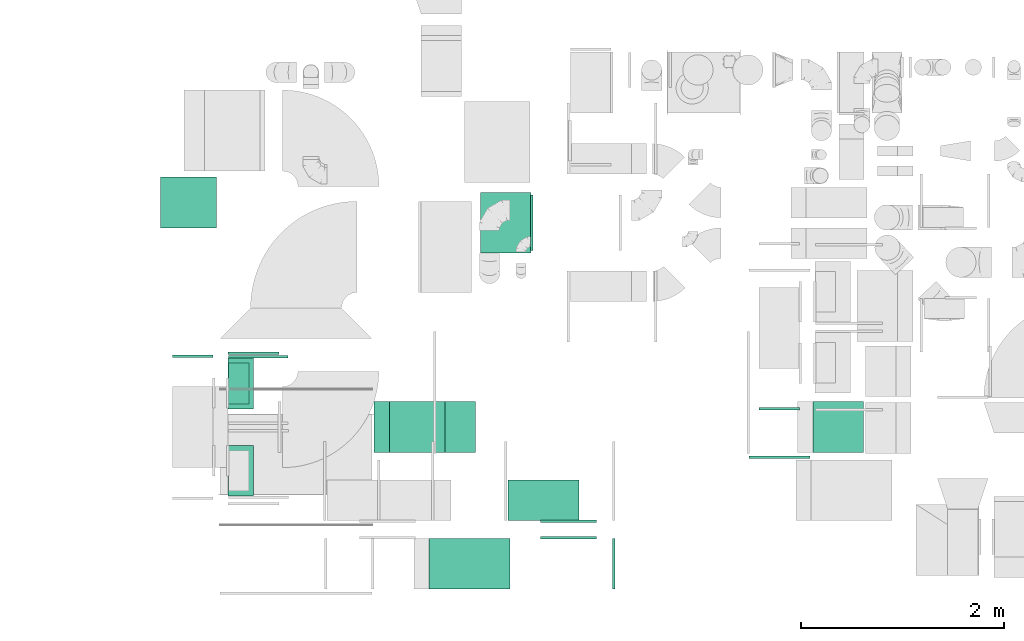
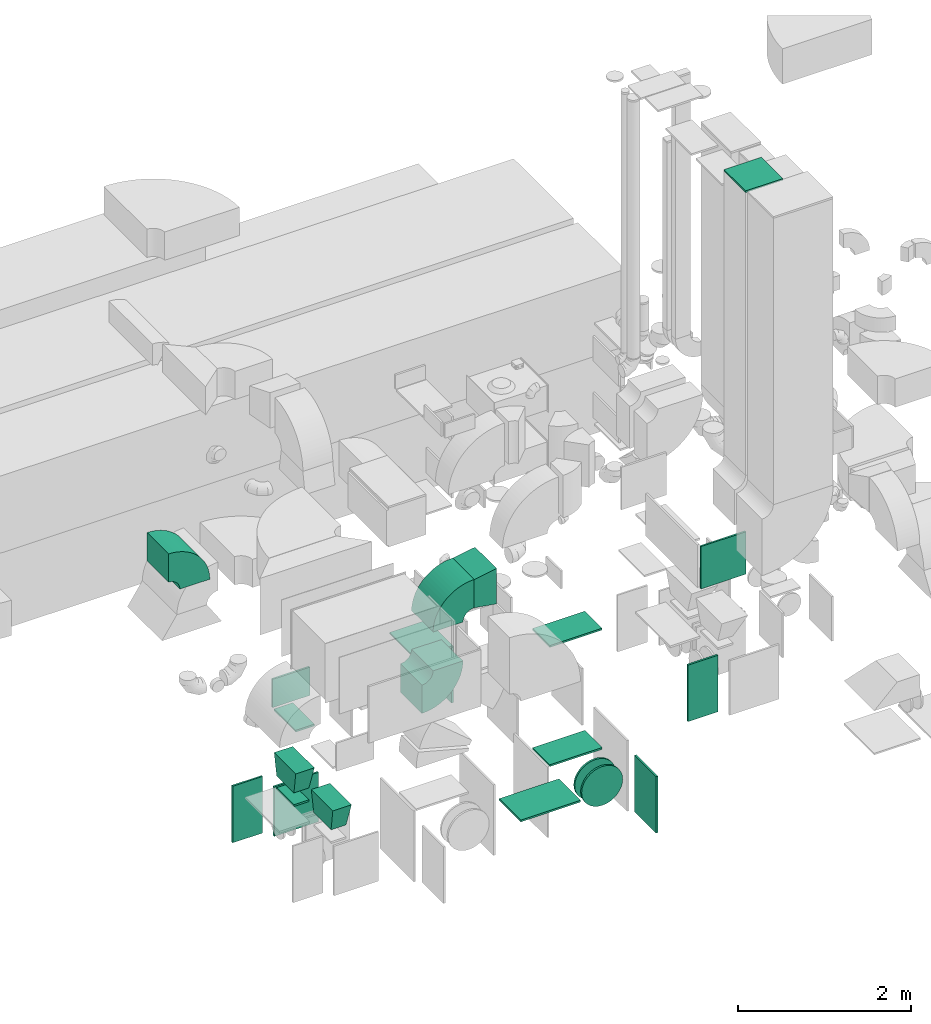
# One storey, part 14 of 59: 22 flow fittings.
"""IFC2X3 building model written with IfcOpenShell, lengths in millimetres."""

import ifcopenshell
import ifcopenshell.guid

model = None  # the IFC model being written
_history = None  # IfcOwnerHistory: only IFC2X3 demands one
_inside = {}  # id of a spatial element -> (the spatial element, [elements in it])
_under = {}  # id of a project, library or spatial element -> (it, [spatial elements below it])
_declared = {}  # id of a project -> (the project, [libraries it declares])
_typed = {}  # id of a type object -> (the type object, [elements of that type])
_made_of = {}  # id of a material, layer set ... -> (it, [elements and type objects made of it])


def new_model(schema):
    """Start an empty IFC model of exactly this schema.

    Asked for "IFC4X3", IfcOpenShell would pick the latest addendum, in which some entities
    have other attributes; the version numbers below select the first issue.
    IFC2X3 requires an IfcOwnerHistory on every rooted entity: one is made here for all.
    """
    global model, _history
    if schema == "IFC4X3":
        model = ifcopenshell.file(schema_version=(4, 3, 0, 0))
    else:
        model = ifcopenshell.file(schema=schema)
    _inside.clear()
    _under.clear()
    _declared.clear()
    _typed.clear()
    _made_of.clear()
    _history = None
    if model.schema == "IFC2X3":
        org = make("IfcOrganization", Name="unknown")
        user = make(
            "IfcPersonAndOrganization",
            ThePerson=make("IfcPerson", FamilyName="unknown"),
            TheOrganization=org,
        )
        app = make(
            "IfcApplication",
            ApplicationDeveloper=org,
            Version="unknown",
            ApplicationFullName="unknown",
            ApplicationIdentifier="unknown",
        )
        _history = make(
            "IfcOwnerHistory",
            OwningUser=user,
            OwningApplication=app,
            ChangeAction="ADDED",
            CreationDate=0,
        )
    return model


def make(cls, **values):
    """One entity of the class cls with the attributes given. An attribute that is None is left unset."""
    return model.create_entity(
        cls, **{name: value for name, value in values.items() if value is not None}
    )


def entity(cls, *values):
    """Any entity or typed value of the class cls, its attributes in the order of the schema. None: left unset."""
    e = model.create_entity(cls)
    for i, value in enumerate(values):
        if value is not None:
            e[i] = value
    return e


def rooted(cls, **values):
    """An entity with a GlobalId (a new one), such as an element, a storey or a relation."""
    return make(cls, GlobalId=ifcopenshell.guid.new(), OwnerHistory=_history, **values)


def si_unit(unit_type, name, prefix=None):
    """IfcSIUnit, for example si_unit("LENGTHUNIT", "METRE", prefix="MILLI")."""
    return make("IfcSIUnit", UnitType=unit_type, Prefix=prefix, Name=name)


def converted_unit(unit_type, name, factor, base, dimensions=None, offset=None):
    """IfcConversionBasedUnit, such as the inch: factor (a typed value) times the base unit."""
    return make(
        "IfcConversionBasedUnit"
        if offset is None
        else "IfcConversionBasedUnitWithOffset",
        ConversionOffset=offset,
        Dimensions=None
        if dimensions is None
        else entity("IfcDimensionalExponents", *dimensions),
        UnitType=unit_type,
        Name=name,
        ConversionFactor=make(
            "IfcMeasureWithUnit", ValueComponent=factor, UnitComponent=base
        ),
    )


def derived_unit(unit_type, elements):
    """IfcDerivedUnit: a product of units, each with its exponent."""
    return make(
        "IfcDerivedUnit",
        Elements=[
            make("IfcDerivedUnitElement", Unit=unit, Exponent=power)
            for unit, power in elements
        ],
        UnitType=unit_type,
    )


def assignment(units):
    """IfcUnitAssignment: the units of a project."""
    return None if units is None else make("IfcUnitAssignment", Units=units)


def point(xyz):
    """IfcCartesianPoint."""
    return None if xyz is None else make("IfcCartesianPoint", Coordinates=xyz)


def direction(xyz):
    """IfcDirection."""
    return None if xyz is None else make("IfcDirection", DirectionRatios=xyz)


def frame(location, z_axis=None, x_axis=None):
    """IfcAxis2Placement3D, a coordinate frame: its origin and axes. An axis left out is left unset."""
    return make(
        "IfcAxis2Placement3D",
        Location=point(location),
        Axis=direction(z_axis),
        RefDirection=direction(x_axis),
    )


def frame_2d(location, x_axis=None):
    """IfcAxis2Placement2D, a coordinate frame in the plane: its origin and x axis."""
    return make(
        "IfcAxis2Placement2D", Location=point(location), RefDirection=direction(x_axis)
    )


def origin():
    """The frame at (0, 0, 0) with its axes left unset."""
    return frame((0.0, 0.0, 0.0))


def origin_2d_with_axis():
    """The frame at (0, 0) in the plane with the x axis (1, 0) written out."""
    return frame_2d((0.0, 0.0), x_axis=(1.0, 0.0))


def place(relative_to, where):
    """IfcLocalPlacement: puts the frame where relative to a parent placement (None: the world)."""
    return make(
        "IfcLocalPlacement", PlacementRelTo=relative_to, RelativePlacement=where
    )


def context(
    kind, dimensions, precision=None, world=None, true_north=None, identifier=None
):
    """IfcGeometricRepresentationContext, for example the 3D "Model" context."""
    return make(
        "IfcGeometricRepresentationContext",
        ContextIdentifier=identifier,
        ContextType=kind,
        CoordinateSpaceDimension=dimensions,
        Precision=precision,
        WorldCoordinateSystem=world,
        TrueNorth=true_north,
    )


def subcontext(parent, identifier, kind, view, scale=None):
    """IfcGeometricRepresentationSubContext, for example "Body" below "Model"."""
    return make(
        "IfcGeometricRepresentationSubContext",
        ContextIdentifier=identifier,
        ContextType=kind,
        ParentContext=parent,
        TargetScale=scale,
        TargetView=view,
    )


def project(units=None, contexts=None):
    """IfcProject with its units and contexts."""
    return rooted(
        "IfcProject",
        Name="project",
        RepresentationContexts=contexts,
        UnitsInContext=assignment(units),
    )


def spatial(cls, under=None, at=None, **own):
    """A site, building, storey or space (cls), placed at a placement, below another one or the project."""
    s = rooted(cls, ObjectPlacement=at, **own)
    if under is not None:
        _under.setdefault(under.id(), (under, []))[1].append(s)
    return s


def polyline(points):
    """IfcPolyline through the points."""
    return make("IfcPolyline", Points=[point(p) for p in points])


def circle_curve(where, radius):
    """IfcCircle in the frame where."""
    return make("IfcCircle", Position=where, Radius=radius)


def parameter(value):
    """IfcParameterValue: where a trimmed curve begins or ends, as a parameter of its basis curve."""
    return model.create_entity("IfcParameterValue", value)


def trimmed(basis, trim1, trim2, sense, master):
    """IfcTrimmedCurve: the piece of a basis curve between two trims."""
    return make(
        "IfcTrimmedCurve",
        BasisCurve=basis,
        Trim1=trim1,
        Trim2=trim2,
        SenseAgreement=sense,
        MasterRepresentation=master,
    )


def segment(curve, same_sense, transition):
    """IfcCompositeCurveSegment."""
    return make(
        "IfcCompositeCurveSegment",
        Transition=transition,
        SameSense=same_sense,
        ParentCurve=curve,
    )


def composite_curve(segments, self_intersect=None):
    """IfcCompositeCurve: segments joined end to end."""
    return make("IfcCompositeCurve", Segments=segments, SelfIntersect=self_intersect)


def profile(cls, at=None, kind="AREA", **sizes):
    """A parametric profile (cls). Its sizes go by their IFC names, for example OverallWidth=200.0."""
    return make(cls, ProfileType=kind, Position=at, **sizes)


def rectangle(**sizes):
    """IfcRectangleProfileDef."""
    return profile("IfcRectangleProfileDef", **sizes)


def outline(outer, holes=None, kind="AREA"):
    """IfcArbitraryClosedProfileDef: a profile drawn as a closed curve; with holes, ...WithVoids."""
    if holes is None:
        return make("IfcArbitraryClosedProfileDef", ProfileType=kind, OuterCurve=outer)
    return make(
        "IfcArbitraryProfileDefWithVoids",
        ProfileType=kind,
        OuterCurve=outer,
        InnerCurves=holes,
    )


def extrude(swept, where, along, depth):
    """IfcExtrudedAreaSolid: the profile swept, set in the frame where, extruded along a direction by depth."""
    return make(
        "IfcExtrudedAreaSolid",
        SweptArea=swept,
        Position=where,
        ExtrudedDirection=direction(along),
        Depth=depth,
    )


def faces_of(points, faces, orient=None, outer=None):
    """IfcFace entities. A face is a list of loops; a loop is a list of indices into points, from 0.

    orient and outer hold one flag for each loop. By default every Orientation is true, the
    first loop of a face is its IfcFaceOuterBound and the others are IfcFaceBound.
    """
    made = []
    for i, loops in enumerate(faces):
        bounds = []
        for j, loop in enumerate(loops):
            is_outer = j == 0 if outer is None else outer[i][j]
            bounds.append(
                make(
                    "IfcFaceOuterBound" if is_outer else "IfcFaceBound",
                    Bound=make("IfcPolyLoop", Polygon=[points[k] for k in loop]),
                    Orientation=True if orient is None else orient[i][j],
                )
            )
        made.append(make("IfcFace", Bounds=bounds))
    return made


def faceted_brep(points, faces, orient=None, outer=None, voids=None):
    """IfcFacetedBrep: a solid bounded by flat faces; with voids (closed shells), ...WithVoids."""
    shared = [point(p) for p in points]
    hull = make("IfcClosedShell", CfsFaces=faces_of(shared, faces, orient, outer))
    if voids is None:
        return make("IfcFacetedBrep", Outer=hull)
    return make(
        "IfcFacetedBrepWithVoids",
        Outer=hull,
        Voids=[
            make(cls, CfsFaces=faces_of(shared, fs, o, b)) for cls, fs, o, b in voids
        ],
    )


def shape(context_of_items, identifier, shape_type, items):
    """IfcShapeRepresentation: the items that make up one representation, for example the "Body"."""
    return make(
        "IfcShapeRepresentation",
        ContextOfItems=context_of_items,
        RepresentationIdentifier=identifier,
        RepresentationType=shape_type,
        Items=items,
    )


def source(mapping_origin, context_of_items, identifier, shape_type, items):
    """IfcRepresentationMap: a shape defined once, which mapped items show again and again."""
    return make(
        "IfcRepresentationMap",
        MappingOrigin=mapping_origin,
        MappedRepresentation=shape(context_of_items, identifier, shape_type, items),
    )


def transform(
    local_origin,
    x_axis=None,
    y_axis=None,
    z_axis=None,
    scale=None,
    scale2=None,
    scale3=None,
    uniform=True,
):
    """IfcCartesianTransformationOperator3D, or its non-uniform kind. x_axis, y_axis, z_axis: its Axis1, 2, 3."""
    if uniform:
        return make(
            "IfcCartesianTransformationOperator3D",
            Axis1=direction(x_axis),
            Axis2=direction(y_axis),
            LocalOrigin=point(local_origin),
            Scale=scale,
            Axis3=direction(z_axis),
        )
    return make(
        "IfcCartesianTransformationOperator3DnonUniform",
        Axis1=direction(x_axis),
        Axis2=direction(y_axis),
        LocalOrigin=point(local_origin),
        Scale=scale,
        Axis3=direction(z_axis),
        Scale2=scale2,
        Scale3=scale3,
    )


def mapped(mapping_source, mapping_target):
    """IfcMappedItem: shows the shape of a source again, moved by a transform."""
    return make(
        "IfcMappedItem", MappingSource=mapping_source, MappingTarget=mapping_target
    )


def material(Name=None, Category=None):
    """IfcMaterial."""
    return make("IfcMaterial", Name=Name, Category=Category)


def made_of(thing, what):
    """Note that an element or type object is made of a material, layer set ...; save() writes the relation."""
    if what is not None:
        _made_of.setdefault(what.id(), (what, []))[1].append(thing)
    return thing


def type_object(cls, material=None, **own):
    """A type object (cls), such as IfcWallType, which elements share."""
    return made_of(rooted(cls, **own), material)


def type_shapes(of_type, sources):
    """Give a type object the sources (RepresentationMaps) that its elements show as mapped items."""
    of_type.RepresentationMaps = sources


def element(
    cls,
    number,
    at=None,
    inside=None,
    cuts=None,
    type_object=None,
    material=None,
    context=None,
    identifier="Body",
    shape_type=None,
    held_by="IfcProductDefinitionShape",
    body=None,
    shapes=None,
    **own,
):
    """One element of the class cls, such as IfcWall. Its Tag is "e" and its number.

    at: its placement. inside: the storey or other place that contains it. cuts: it is an
    opening in that element (IfcRelVoidsElement). A single representation is given by context,
    identifier, shape_type and body (its items); several are given by shapes. held_by: the class
    of the entity that holds the representations. save() writes the other relations.
    """
    e = rooted(cls, Tag="e%d" % number, ObjectPlacement=at, **own)
    if body is not None:
        shapes = [shape(context, identifier, shape_type, body)]
    if shapes is not None:
        e.Representation = make(held_by, Representations=shapes)
    if inside is not None:
        _inside.setdefault(inside.id(), (inside, []))[1].append(e)
    if cuts is not None:
        rooted(
            "IfcRelVoidsElement", RelatingBuildingElement=cuts, RelatedOpeningElement=e
        )
    if type_object is not None:
        _typed.setdefault(type_object.id(), (type_object, []))[1].append(e)
    return made_of(e, material)


def aggregate(whole, parts):
    """IfcRelAggregates: a whole, such as a stair, and the parts it consists of."""
    return rooted("IfcRelAggregates", RelatingObject=whole, RelatedObjects=parts)


def save(model, path):
    """Write the relations noted so far, then the file.

    IfcRelAggregates (storeys below a building ...), IfcRelContainedInSpatialStructure (elements
    in a storey), IfcRelDefinesByType, IfcRelAssociatesMaterial and IfcRelDeclares: one each for
    every whole, place, type object, material and project.
    """
    for whole, parts in _under.values():
        aggregate(whole, parts)
    for where, things in _inside.values():
        rooted(
            "IfcRelContainedInSpatialStructure",
            RelatedElements=things,
            RelatingStructure=where,
        )
    for kind, things in _typed.values():
        rooted("IfcRelDefinesByType", RelatedObjects=things, RelatingType=kind)
    for what, things in _made_of.values():
        rooted("IfcRelAssociatesMaterial", RelatedObjects=things, RelatingMaterial=what)
    for by, libraries in _declared.values():
        rooted("IfcRelDeclares", RelatingContext=by, RelatedDefinitions=libraries)
    model.write(path)


model = new_model("IFC2X3")

# Units and contexts
model_context = context("Model", 3, precision=0.01, world=origin(), true_north=direction((6.12303176911189e-17, 1.0)))
body_context = subcontext(model_context, "Body", "Model", "MODEL_VIEW")
ifc_project = project(units=[si_unit("LENGTHUNIT", "METRE", prefix="MILLI"), si_unit("AREAUNIT", "SQUARE_METRE"), si_unit("VOLUMEUNIT", "CUBIC_METRE"), converted_unit("PLANEANGLEUNIT", "DEGREE", entity("IfcRatioMeasure", 0.0174532925199433), si_unit("PLANEANGLEUNIT", "RADIAN"), dimensions=[0, 0, 0, 0, 0, 0, 0]), si_unit("MASSUNIT", "GRAM", prefix="KILO"), derived_unit("MASSDENSITYUNIT", [(si_unit("MASSUNIT", "GRAM", prefix="KILO"), 1), (si_unit("LENGTHUNIT", "METRE"), -3)]), derived_unit("MOMENTOFINERTIAUNIT", [(si_unit("LENGTHUNIT", "METRE"), 4)]), si_unit("TIMEUNIT", "SECOND"), si_unit("FREQUENCYUNIT", "HERTZ"), si_unit("THERMODYNAMICTEMPERATUREUNIT", "DEGREE_CELSIUS"), derived_unit("THERMALTRANSMITTANCEUNIT", [(si_unit("MASSUNIT", "GRAM", prefix="KILO"), 1), (si_unit("THERMODYNAMICTEMPERATUREUNIT", "KELVIN"), -1), (si_unit("TIMEUNIT", "SECOND"), -3)]), derived_unit("VOLUMETRICFLOWRATEUNIT", [(si_unit("LENGTHUNIT", "METRE"), 3), (si_unit("TIMEUNIT", "SECOND"), -1)]), derived_unit("MASSFLOWRATEUNIT", [(si_unit("MASSUNIT", "GRAM", prefix="KILO"), 1), (si_unit("TIMEUNIT", "SECOND"), -1)]), derived_unit("ROTATIONALFREQUENCYUNIT", [(si_unit("TIMEUNIT", "SECOND"), -1)]), si_unit("ELECTRICCURRENTUNIT", "AMPERE"), si_unit("ELECTRICVOLTAGEUNIT", "VOLT"), si_unit("POWERUNIT", "WATT"), si_unit("FORCEUNIT", "NEWTON", prefix="KILO"), si_unit("ILLUMINANCEUNIT", "LUX"), si_unit("LUMINOUSFLUXUNIT", "LUMEN"), si_unit("LUMINOUSINTENSITYUNIT", "CANDELA"), derived_unit("USERDEFINED", [(si_unit("MASSUNIT", "GRAM", prefix="KILO"), -1), (si_unit("LENGTHUNIT", "METRE"), -2), (si_unit("TIMEUNIT", "SECOND"), 3), (si_unit("LUMINOUSFLUXUNIT", "LUMEN"), 1)]), derived_unit("LINEARVELOCITYUNIT", [(si_unit("LENGTHUNIT", "METRE"), 1), (si_unit("TIMEUNIT", "SECOND"), -1)]), si_unit("PRESSUREUNIT", "PASCAL"), derived_unit("USERDEFINED", [(si_unit("LENGTHUNIT", "METRE"), -2), (si_unit("MASSUNIT", "GRAM", prefix="KILO"), 1), (si_unit("TIMEUNIT", "SECOND"), -2)]), derived_unit("LINEARFORCEUNIT", [(si_unit("MASSUNIT", "GRAM", prefix="KILO"), 1), (si_unit("LENGTHUNIT", "METRE"), 1), (si_unit("TIMEUNIT", "SECOND"), -2), (si_unit("LENGTHUNIT", "METRE"), -1)]), derived_unit("PLANARFORCEUNIT", [(si_unit("MASSUNIT", "GRAM", prefix="KILO"), 1), (si_unit("LENGTHUNIT", "METRE"), 1), (si_unit("TIMEUNIT", "SECOND"), -2), (si_unit("LENGTHUNIT", "METRE"), -2)])], contexts=[model_context])

# Site, building, storey
site_placement = place(None, origin())
site = spatial("IfcSite", under=ifc_project, at=site_placement, CompositionType="ELEMENT")
building_placement = place(site_placement, origin())
building = spatial("IfcBuilding", under=site, at=building_placement, CompositionType="ELEMENT")
storey_placement = place(building_placement, frame((0.0, 0.0, 28200.0)))
storey = spatial("IfcBuildingStorey", under=building, at=storey_placement, CompositionType="ELEMENT", Elevation=28200.0)

# Flow fittings
ifc_material = material()
duct_fitting_type_1 = type_object("IfcDuctFittingType", PredefinedType="NOTDEFINED", material=ifc_material)
shared_shape_1 = source(origin(), body_context, "Body", "SweptSolid", [
    extrude(rectangle(XDim=26.0960000000006, YDim=400.0, at=origin_2d_with_axis()), frame((6.95, 0.0, -100.0)), (0.0, 0.0, 1.0), 200.0),
])
type_shapes(duct_fitting_type_1, [shared_shape_1])
flow_fitting_1_placement = place(storey_placement, frame((42620.03, 9903.67, 900.0), z_axis=(1.0, 0.0, 0.0), x_axis=(0.0, 0.0, 1.0)))
element("IfcFlowFitting", 1, at=flow_fitting_1_placement, inside=storey, type_object=duct_fitting_type_1, material=ifc_material, context=body_context, shape_type="MappedRepresentation", body=[
    mapped(shared_shape_1, transform((0.0, 0.0, 0.0), scale=1.0)),
])
duct_fitting_type_2 = type_object("IfcDuctFittingType", PredefinedType="NOTDEFINED", material=ifc_material)
shared_shape_2 = source(origin(), body_context, "Body", "SweptSolid", [
    extrude(rectangle(XDim=24.9999999999999, YDim=500.0, at=origin_2d_with_axis()), frame((12.5, 0.0, -200.0)), (0.0, 0.0, 1.0), 400.0),
])
type_shapes(duct_fitting_type_2, [shared_shape_2])
flow_fitting_2_placement = place(storey_placement, frame((42765.03, 10189.25, 2200.0), z_axis=(0.0, 0.0, 1.0), x_axis=(0.0, 1.0, 0.0)))
element("IfcFlowFitting", 2, at=flow_fitting_2_placement, inside=storey, type_object=duct_fitting_type_2, material=ifc_material, context=body_context, shape_type="MappedRepresentation", body=[
    mapped(shared_shape_2, transform((0.0, 0.0, 0.0), scale=1.0)),
])
duct_fitting_type_3 = type_object("IfcDuctFittingType", PredefinedType="NOTDEFINED", material=ifc_material)
shared_shape_3 = source(origin(), body_context, "Body", "SweptSolid", [
    extrude(rectangle(XDim=24.9999999999999, YDim=600.0, at=origin_2d_with_axis()), frame((12.5, 0.0, -250.0)), (0.0, 0.0, 1.0), 500.0),
])
type_shapes(duct_fitting_type_3, [shared_shape_3])
flow_fitting_3_placement = place(storey_placement, frame((45254.94, 11489.6, 1200.0), z_axis=(1.0, 0.0, 0.0), x_axis=(0.0, 0.0, 1.0)))
element("IfcFlowFitting", 3, at=flow_fitting_3_placement, inside=storey, type_object=duct_fitting_type_3, material=ifc_material, context=body_context, shape_type="MappedRepresentation", body=[
    mapped(shared_shape_3, transform((0.0, 0.0, 0.0), scale=1.0)),
])
duct_fitting_type_4 = type_object("IfcDuctFittingType", PredefinedType="NOTDEFINED", material=ifc_material)
shared_shape_4 = source(origin(), body_context, "Body", "SweptSolid", [
    extrude(rectangle(XDim=24.9999999999999, YDim=500.0, at=origin_2d_with_axis()), frame((12.5, 0.0, -400.0)), (0.0, 0.0, 1.0), 800.0),
])
type_shapes(duct_fitting_type_4, [shared_shape_4])
flow_fitting_4_placement = place(storey_placement, frame((46308.79, 8124.6, 700.0)))
element("IfcFlowFitting", 4, at=flow_fitting_4_placement, inside=storey, type_object=duct_fitting_type_4, material=ifc_material, context=body_context, shape_type="MappedRepresentation", body=[
    mapped(shared_shape_4, transform((0.0, 0.0, 0.0), scale=1.0)),
])
duct_fitting_type_5 = type_object("IfcDuctFittingType", PredefinedType="NOTDEFINED", material=ifc_material)
shared_shape_5 = source(origin(), body_context, "Body", "SweptSolid", [
    extrude(rectangle(XDim=500.0, YDim=26.0960000001386, at=origin_2d_with_axis()), frame((6.95, 0.0, -125.0), z_axis=(0.0, 0.0, 1.0), x_axis=(0.0, -1.0, 0.0)), (0.0, 0.0, 1.0), 250.0),
])
type_shapes(duct_fitting_type_5, [shared_shape_5])
flow_fitting_5_placement = place(storey_placement, frame((42640.03, 9903.67, 2000.0), z_axis=(-1.0, 0.0, 0.0), x_axis=(0.0, 0.0, -1.0)))
element("IfcFlowFitting", 5, at=flow_fitting_5_placement, inside=storey, type_object=duct_fitting_type_5, material=ifc_material, context=body_context, shape_type="MappedRepresentation", body=[
    mapped(shared_shape_5, transform((0.0, 0.0, 0.0), scale=1.0)),
])
duct_fitting_type_6 = type_object("IfcDuctFittingType", PredefinedType="NOTDEFINED", material=ifc_material)
shared_shape_6 = source(origin(), body_context, "Body", "SweptSolid", [
    extrude(rectangle(XDim=500.0, YDim=26.0960000000953, at=origin_2d_with_axis()), frame((6.95, 0.0, -400.0), z_axis=(0.0, 0.0, 1.0), x_axis=(0.0, -1.0, 0.0)), (0.0, 0.0, 1.0), 800.0),
])
type_shapes(duct_fitting_type_6, [shared_shape_6])
flow_fitting_6_placement = place(storey_placement, frame((44898.71, 8124.6, 1100.0), z_axis=(1.0, 0.0, 0.0), x_axis=(0.0, 0.0, 1.0)))
element("IfcFlowFitting", 6, at=flow_fitting_6_placement, inside=storey, type_object=duct_fitting_type_6, material=ifc_material, context=body_context, shape_type="MappedRepresentation", body=[
    mapped(shared_shape_6, transform((0.0, 0.0, 0.0), scale=1.0)),
])
duct_fitting_type_7 = type_object("IfcDuctFittingType", PredefinedType="NOTDEFINED", material=ifc_material)
shared_shape_7 = source(origin(), body_context, "Body", "SweptSolid", [
    extrude(rectangle(XDim=24.9999999999999, YDim=600.0, at=origin_2d_with_axis()), frame((12.5, 0.0, -300.0)), (0.0, 0.0, 1.0), 600.0),
])
type_shapes(duct_fitting_type_7, [shared_shape_7])
flow_fitting_7_placement = place(storey_placement, frame((47955.88, 9190.49, 2800.0), z_axis=(0.0, 0.0, 1.0), x_axis=(0.0, -1.0, 0.0)))
element("IfcFlowFitting", 7, at=flow_fitting_7_placement, inside=storey, type_object=duct_fitting_type_7, material=ifc_material, context=body_context, shape_type="MappedRepresentation", body=[
    mapped(shared_shape_7, transform((0.0, 0.0, 0.0), scale=1.0)),
])
duct_fitting_type_8 = type_object("IfcDuctFittingType", PredefinedType="NOTDEFINED", material=ifc_material)
shared_shape_8 = source(origin(), body_context, "Body", "SweptSolid", [
    extrude(rectangle(XDim=24.9999999999999, YDim=400.0, at=origin_2d_with_axis()), frame((12.5, 0.0, -400.0)), (0.0, 0.0, 1.0), 800.0),
])
type_shapes(duct_fitting_type_8, [shared_shape_8])
for number, where, z_axis, x_axis in (
    (8, (42165.03, 10158.46, 700.0), (0.0, 0.0, 1.0), (0.0, 1.0, 0.0)),
    (9, (47955.03, 9665.16, 700.0), (0.0, 0.0, 1.0), (0.0, -1.0, 0.0)),
):
    element("IfcFlowFitting", number, at=place(storey_placement, frame(where, z_axis=z_axis, x_axis=x_axis)), inside=storey, type_object=duct_fitting_type_8, material=ifc_material, context=body_context, shape_type="MappedRepresentation", body=[
        mapped(shared_shape_8, transform((0.0, 0.0, 0.0), scale=1.0)),
    ])
duct_fitting_type_9 = type_object("IfcDuctFittingType", PredefinedType="NOTDEFINED", material=ifc_material)
shared_shape_9 = source(origin(), body_context, "Body", "SweptSolid", [
    extrude(rectangle(XDim=400.0, YDim=26.0960000000087, at=origin_2d_with_axis()), frame((6.95, 0.0, -350.0), z_axis=(0.0, 0.0, 1.0), x_axis=(0.0, -1.0, 0.0)), (0.0, 0.0, 1.0), 700.0),
])
type_shapes(duct_fitting_type_9, [shared_shape_9])
for number, where, z_axis, x_axis in (
    (10, (45627.02, 8749.6, 1200.0), (1.0, 0.0, 0.0), (0.0, 0.0, 1.0)),
    (11, (45627.02, 8749.6, 2900.0), (1.0, 0.0, 0.0), (0.0, 0.0, -1.0)),
):
    element("IfcFlowFitting", number, at=place(storey_placement, frame(where, z_axis=z_axis, x_axis=x_axis)), inside=storey, type_object=duct_fitting_type_9, material=ifc_material, context=body_context, shape_type="MappedRepresentation", body=[
        mapped(shared_shape_9, transform((0.0, 0.0, 0.0), scale=1.0)),
    ])
duct_fitting_type_10 = type_object("IfcDuctFittingType", PredefinedType="NOTDEFINED", material=ifc_material)
shared_shape_10 = source(origin(), body_context, "Body", "SweptSolid", [
    extrude(outline(polyline([(-115.08, -221.94), (189.06, -221.94), (106.86, 271.26), (-180.84, 172.62), (-115.08, -221.94)])), frame((150.0, -250.0, 0.0), z_axis=(0.0, 1.0, 0.0), x_axis=(0.986393923832159, 0.0, 0.164398987305264)), (0.0, 0.0, 1.0), 500.0),
])
type_shapes(duct_fitting_type_10, [shared_shape_10])
flow_fitting_8_placement = place(storey_placement, frame((44655.04, 9473.67, 3450.0)))
element("IfcFlowFitting", 12, at=flow_fitting_8_placement, inside=storey, type_object=duct_fitting_type_10, material=ifc_material, context=body_context, shape_type="MappedRepresentation", body=[
    mapped(shared_shape_10, transform((0.0, 0.0, 0.0), scale=1.0)),
])
duct_fitting_type_11 = type_object("IfcDuctFittingType", PredefinedType="NOTDEFINED", material=ifc_material)
shared_shape_11 = source(origin(), body_context, "Body", "SweptSolid", [
    extrude(rectangle(XDim=24.9999999999999, YDim=590.0, at=origin_2d_with_axis()), frame((12.5, 0.0, -350.0)), (0.0, 0.0, 1.0), 700.0),
])
type_shapes(duct_fitting_type_11, [shared_shape_11])
flow_fitting_9_placement = place(storey_placement, frame((42812.57, 10153.67, 550.0), z_axis=(0.0, 0.0, 1.0), x_axis=(0.0, 1.0, 0.0)))
element("IfcFlowFitting", 13, at=flow_fitting_9_placement, inside=storey, type_object=duct_fitting_type_11, material=ifc_material, context=body_context, shape_type="MappedRepresentation", body=[
    mapped(shared_shape_11, transform((0.0, 0.0, 0.0), scale=1.0)),
])
duct_fitting_type_12 = type_object("IfcDuctFittingType", PredefinedType="NOTDEFINED", material=ifc_material)
shared_shape_12 = source(origin(), body_context, "Body", "SweptSolid", [
    extrude(rectangle(XDim=24.9999999999999, YDim=500.0, at=origin_2d_with_axis()), frame((12.5, 0.0, -250.0)), (0.0, 0.0, 1.0), 500.0),
])
type_shapes(duct_fitting_type_12, [shared_shape_12])
flow_fitting_10_placement = place(storey_placement, frame((48535.0, 9473.67, 7850.0), z_axis=(-1.0, 0.0, 0.0), x_axis=(0.0, 0.0, 1.0)))
element("IfcFlowFitting", 14, at=flow_fitting_10_placement, inside=storey, type_object=duct_fitting_type_12, material=ifc_material, context=body_context, shape_type="MappedRepresentation", body=[
    mapped(shared_shape_12, transform((0.0, 0.0, 0.0), scale=1.0)),
])
duct_fitting_type_13 = type_object("IfcDuctFittingType", PredefinedType="NOTDEFINED", material=ifc_material)
shared_shape_13 = source(origin(), body_context, "Body", "SweptSolid", [
    extrude(rectangle(XDim=26.0960000000012, YDim=800.0, at=origin_2d_with_axis()), frame((6.95, 0.0, -275.0)), (0.0, 0.0, 1.0), 550.0),
])
type_shapes(duct_fitting_type_13, [shared_shape_13])
flow_fitting_11_placement = place(storey_placement, frame((45504.94, 11489.6, 800.0), z_axis=(0.0, -1.0, 0.0), x_axis=(1.0, 0.0, 0.0)))
element("IfcFlowFitting", 15, at=flow_fitting_11_placement, inside=storey, type_object=duct_fitting_type_13, material=ifc_material, context=body_context, shape_type="MappedRepresentation", body=[
    mapped(shared_shape_13, transform((0.0, 0.0, 0.0), scale=1.0)),
])
duct_fitting_type_14 = type_object("IfcDuctFittingType", PredefinedType="NOTDEFINED", material=ifc_material)
shared_shape_14 = source(origin(), body_context, "Body", "Brep", [
    faceted_brep([(20.0, 275.0, 0.0), (20.0, 269.72, 53.65), (20.0, 254.07, 105.24), (20.0, 228.65, 152.78), (20.0, 194.45, 194.45), (20.0, 152.78, 228.65), (20.0, 105.24, 254.07), (20.0, 53.65, 269.72), (20.0, 0.0, 275.0), (20.0, -53.65, 269.72), (20.0, -105.24, 254.07), (20.0, -152.78, 228.65), (20.0, -194.45, 194.45), (20.0, -228.65, 152.78), (20.0, -254.07, 105.24), (20.0, -269.72, 53.65), (20.0, -275.0, 0.0), (20.0, -269.72, -53.65), (20.0, -254.07, -105.24), (20.0, -228.65, -152.78), (20.0, -194.45, -194.45), (20.0, -152.78, -228.65), (20.0, -105.24, -254.07), (20.0, -53.65, -269.72), (20.0, 0.0, -275.0), (20.0, 53.65, -269.72), (20.0, 105.24, -254.07), (20.0, 152.78, -228.65), (20.0, 194.45, -194.45), (20.0, 228.65, -152.78), (20.0, 254.07, -105.24), (20.0, 269.72, -53.65), (0.0, 0.0, 275.0), (0.0, 35.96, 271.46), (-6.1, 26.82, 272.36), (-6.1, 0.0, 275.0), (0.0, 53.65, 269.72), (-6.1, 53.65, 269.72), (0.0, 79.44, 261.89), (0.0, 105.24, 254.07), (-6.1, 79.44, 261.89), (-6.1, 105.24, 254.07), (0.0, 129.01, 241.36), (0.0, 152.78, 228.65), (-6.1, 129.01, 241.36), (-6.1, 152.78, 228.65), (0.0, 194.45, 194.45), (0.0, 173.62, 211.55), (-6.1, 173.62, 211.55), (-6.1, 194.45, 194.45), (0.0, 228.65, 152.78), (0.0, 241.36, 129.01), (0.0, 254.07, 105.24), (-6.1, 254.07, 105.24), (-6.1, 241.36, 129.01), (-6.1, 228.65, 152.78), (0.0, 269.72, 53.65), (0.0, 261.89, 79.44), (-6.1, 269.72, 53.65), (-6.1, 261.89, 79.44), (0.0, 275.0, 0.0), (0.0, 271.46, 35.96), (-6.1, 272.36, 26.82), (-6.1, 275.0, 0.0), (0.0, 211.55, 173.62), (-6.1, 211.55, 173.62), (0.0, 271.46, -35.96), (-6.1, 272.36, -26.82), (0.0, 269.72, -53.65), (-6.1, 269.72, -53.65), (0.0, 261.89, -79.44), (0.0, 254.07, -105.24), (-6.1, 261.89, -79.44), (-6.1, 254.07, -105.24), (0.0, 241.36, -129.01), (0.0, 228.65, -152.78), (-6.1, 241.36, -129.01), (-6.1, 228.65, -152.78), (0.0, 194.45, -194.45), (0.0, 211.55, -173.62), (-6.1, 211.55, -173.62), (-6.1, 194.45, -194.45), (0.0, 105.24, -254.07), (0.0, 129.01, -241.36), (-6.1, 105.24, -254.07), (-6.1, 129.01, -241.36), (0.0, 152.78, -228.65), (-6.1, 152.78, -228.65), (0.0, 53.65, -269.72), (0.0, 79.44, -261.89), (-6.1, 53.65, -269.72), (-6.1, 79.44, -261.89), (0.0, 0.0, -275.0), (0.0, 35.96, -271.46), (-6.1, 26.82, -272.36), (-6.1, 0.0, -275.0), (0.0, 173.62, -211.55), (-6.1, 173.62, -211.55), (0.0, -35.96, -271.46), (-6.1, -26.82, -272.36), (0.0, -53.65, -269.72), (-6.1, -53.65, -269.72), (0.0, -79.44, -261.89), (0.0, -105.24, -254.07), (-6.1, -79.44, -261.89), (-6.1, -105.24, -254.07), (0.0, -129.01, -241.36), (0.0, -152.78, -228.65), (-6.1, -129.01, -241.36), (-6.1, -152.78, -228.65), (0.0, -194.45, -194.45), (0.0, -173.62, -211.55), (-6.1, -173.62, -211.55), (-6.1, -194.45, -194.45), (0.0, -254.07, -105.24), (0.0, -241.36, -129.01), (-6.1, -254.07, -105.24), (-6.1, -241.36, -129.01), (0.0, -228.65, -152.78), (-6.1, -228.65, -152.78), (0.0, -269.72, -53.65), (0.0, -261.89, -79.44), (-6.1, -269.72, -53.65), (-6.1, -261.89, -79.44), (0.0, -275.0, 0.0), (0.0, -271.46, -35.96), (-6.1, -272.36, -26.82), (-6.1, -275.0, 0.0), (0.0, -211.55, -173.62), (-6.1, -211.55, -173.62), (0.0, -271.46, 35.96), (-6.1, -272.36, 26.82), (0.0, -269.72, 53.65), (-6.1, -269.72, 53.65), (0.0, -261.89, 79.44), (0.0, -254.07, 105.24), (-6.1, -261.89, 79.44), (-6.1, -254.07, 105.24), (0.0, -241.36, 129.01), (0.0, -228.65, 152.78), (-6.1, -241.36, 129.01), (-6.1, -228.65, 152.78), (0.0, -194.45, 194.45), (0.0, -211.55, 173.62), (-6.1, -211.55, 173.62), (-6.1, -194.45, 194.45), (0.0, -152.78, 228.65), (0.0, -129.01, 241.36), (0.0, -105.24, 254.07), (-6.1, -129.01, 241.36), (-6.1, -105.24, 254.07), (-6.1, -152.78, 228.65), (0.0, -53.65, 269.72), (0.0, -79.44, 261.89), (-6.1, -53.65, 269.72), (-6.1, -79.44, 261.89), (0.0, -35.96, 271.46), (-6.1, -26.82, 272.36), (0.0, -173.62, 211.55), (-6.1, -173.62, 211.55)], [[[0, 1, 2, 3, 4, 5, 6, 7, 8, 9, 10, 11, 12, 13, 14, 15, 16, 17, 18, 19, 20, 21, 22, 23, 24, 25, 26, 27, 28, 29, 30, 31]], [[32, 8, 7]], [[7, 33, 32]], [[32, 33, 34]], [[35, 32, 34]], [[7, 36, 33]], [[36, 37, 33]], [[33, 37, 34]], [[7, 6, 36]], [[6, 38, 36]], [[6, 39, 38]], [[40, 38, 39]], [[39, 41, 40]], [[37, 38, 40]], [[38, 37, 36]], [[5, 39, 6]], [[5, 42, 39]], [[5, 43, 42]], [[42, 43, 44]], [[43, 45, 44]], [[41, 42, 44]], [[39, 42, 41]], [[4, 46, 47]], [[4, 47, 43]], [[43, 5, 4]], [[46, 48, 47]], [[49, 48, 46]], [[48, 45, 47]], [[45, 43, 47]], [[3, 2, 50]], [[2, 51, 50]], [[2, 52, 51]], [[51, 52, 53]], [[53, 54, 51]], [[55, 51, 54]], [[55, 50, 51]], [[2, 1, 56]], [[2, 56, 57]], [[2, 57, 52]], [[57, 56, 58]], [[57, 58, 59]], [[59, 52, 57]], [[52, 59, 53]], [[60, 1, 0]], [[1, 60, 61]], [[60, 62, 61]], [[60, 63, 62]], [[58, 61, 62]], [[61, 58, 56]], [[1, 61, 56]], [[3, 50, 64]], [[3, 64, 46]], [[3, 46, 4]], [[50, 65, 64]], [[50, 55, 65]], [[64, 65, 49]], [[49, 46, 64]], [[60, 0, 31]], [[31, 66, 60]], [[60, 66, 67]], [[63, 60, 67]], [[31, 68, 66]], [[68, 69, 66]], [[66, 69, 67]], [[31, 30, 68]], [[30, 70, 68]], [[30, 71, 70]], [[72, 70, 71]], [[71, 73, 72]], [[69, 70, 72]], [[70, 69, 68]], [[29, 71, 30]], [[29, 74, 71]], [[29, 75, 74]], [[74, 75, 76]], [[75, 77, 76]], [[73, 74, 76]], [[71, 74, 73]], [[28, 78, 79]], [[28, 79, 75]], [[75, 29, 28]], [[78, 80, 79]], [[81, 80, 78]], [[80, 77, 79]], [[77, 75, 79]], [[82, 27, 26]], [[27, 82, 83]], [[83, 82, 84]], [[83, 84, 85]], [[85, 86, 83]], [[86, 85, 87]], [[27, 83, 86]], [[88, 26, 25]], [[26, 88, 89]], [[89, 88, 90]], [[89, 90, 91]], [[91, 82, 89]], [[82, 91, 84]], [[26, 89, 82]], [[92, 25, 24]], [[25, 92, 93]], [[92, 94, 93]], [[92, 95, 94]], [[90, 93, 94]], [[93, 90, 88]], [[25, 93, 88]], [[27, 86, 96]], [[27, 96, 78]], [[27, 78, 28]], [[86, 87, 96]], [[96, 87, 97]], [[96, 97, 81]], [[81, 78, 96]], [[92, 24, 23]], [[23, 98, 92]], [[92, 98, 99]], [[95, 92, 99]], [[23, 100, 98]], [[100, 101, 98]], [[98, 101, 99]], [[23, 22, 100]], [[22, 102, 100]], [[22, 103, 102]], [[104, 102, 103]], [[103, 105, 104]], [[101, 102, 104]], [[102, 101, 100]], [[21, 103, 22]], [[21, 106, 103]], [[21, 107, 106]], [[106, 107, 108]], [[107, 109, 108]], [[105, 106, 108]], [[103, 106, 105]], [[20, 110, 111]], [[20, 111, 107]], [[107, 21, 20]], [[110, 112, 111]], [[113, 112, 110]], [[112, 109, 111]], [[109, 107, 111]], [[114, 19, 18]], [[19, 114, 115]], [[115, 114, 116]], [[115, 116, 117]], [[117, 118, 115]], [[118, 117, 119]], [[19, 115, 118]], [[18, 17, 120]], [[18, 120, 121]], [[18, 121, 114]], [[121, 120, 122]], [[121, 122, 123]], [[123, 114, 121]], [[114, 123, 116]], [[16, 124, 17]], [[17, 124, 125]], [[124, 126, 125]], [[124, 127, 126]], [[122, 125, 126]], [[125, 122, 120]], [[17, 125, 120]], [[20, 118, 128]], [[118, 20, 19]], [[20, 128, 110]], [[118, 119, 128]], [[128, 119, 129]], [[113, 128, 129]], [[128, 113, 110]], [[124, 16, 15]], [[15, 130, 124]], [[124, 130, 131]], [[127, 124, 131]], [[15, 132, 130]], [[132, 133, 130]], [[130, 133, 131]], [[15, 14, 132]], [[14, 134, 132]], [[14, 135, 134]], [[136, 134, 135]], [[135, 137, 136]], [[133, 134, 136]], [[134, 133, 132]], [[13, 135, 14]], [[13, 138, 135]], [[13, 139, 138]], [[138, 139, 140]], [[139, 141, 140]], [[137, 138, 140]], [[135, 138, 137]], [[12, 142, 143]], [[12, 143, 139]], [[139, 13, 12]], [[142, 144, 143]], [[145, 144, 142]], [[144, 141, 143]], [[141, 139, 143]], [[11, 10, 146]], [[10, 147, 146]], [[10, 148, 147]], [[148, 149, 147]], [[148, 150, 149]], [[151, 147, 149]], [[146, 147, 151]], [[10, 9, 152]], [[10, 152, 153]], [[10, 153, 148]], [[153, 152, 154]], [[153, 154, 155]], [[155, 148, 153]], [[148, 155, 150]], [[32, 9, 8]], [[9, 32, 156]], [[32, 157, 156]], [[32, 35, 157]], [[154, 156, 157]], [[156, 154, 152]], [[9, 156, 152]], [[12, 146, 158]], [[146, 12, 11]], [[12, 158, 142]], [[146, 159, 158]], [[146, 151, 159]], [[158, 159, 145]], [[145, 142, 158]], [[35, 34, 37, 40, 41, 44, 45, 48, 49, 65, 55, 54, 53, 59, 58, 62, 63, 67, 69, 72, 73, 76, 77, 80, 81, 97, 87, 85, 84, 91, 90, 94, 95, 99, 101, 104, 105, 108, 109, 112, 113, 129, 119, 117, 116, 123, 122, 126, 127, 131, 133, 136, 137, 140, 141, 144, 145, 159, 151, 149, 150, 155, 154, 157]]]),
])
type_shapes(duct_fitting_type_14, [shared_shape_14])
for number, where, z_axis, x_axis in (
    (16, (45873.95, 8549.6, 821.95), (0.0, 0.0, 1.0), (0.0, -1.0, 0.0)),
    (17, (45873.95, 8374.6, 821.95), (0.0, 0.0, -1.0), (0.0, 1.0, 0.0)),
):
    element("IfcFlowFitting", number, at=place(storey_placement, frame(where, z_axis=z_axis, x_axis=x_axis)), inside=storey, type_object=duct_fitting_type_14, material=ifc_material, context=body_context, shape_type="MappedRepresentation", body=[
        mapped(shared_shape_14, transform((0.0, 0.0, 0.0), scale=1.0)),
    ])
duct_fitting_type_15 = type_object("IfcDuctFittingType", PredefinedType="NOTDEFINED", material=ifc_material)
shared_shape_15 = source(origin(), body_context, "Body", "Brep", [
    faceted_brep([(300.0, -250.0, 105.0), (300.0, -250.0, -145.0), (300.0, 250.0, -145.0), (300.0, 250.0, 105.0), (0.0, -200.0, 100.0), (0.0, 200.0, 100.0), (0.0, 200.0, -100.0), (0.0, -200.0, -100.0)], [[[0, 1, 2, 3]], [[4, 5, 6, 7]], [[4, 7, 1, 0]], [[7, 6, 2, 1]], [[6, 5, 3, 2]], [[5, 4, 0, 3]]]),
])
type_shapes(duct_fitting_type_15, [shared_shape_15])
for number, where, z_axis, x_axis in (
    (18, (42620.03, 9043.67, 1087.0), (-1.0, 0.0, 0.0), (0.0, 0.0, 1.0)),
    (19, (42620.03, 9903.67, 1087.0), (-1.0, 0.0, 0.0), (0.0, 0.0, 1.0)),
):
    element("IfcFlowFitting", number, at=place(storey_placement, frame(where, z_axis=z_axis, x_axis=x_axis)), inside=storey, type_object=duct_fitting_type_15, material=ifc_material, context=body_context, shape_type="MappedRepresentation", body=[
        mapped(shared_shape_15, transform((0.0, 0.0, 0.0), scale=1.0)),
    ])
duct_fitting_type_16 = type_object("IfcDuctFittingType", PredefinedType="NOTDEFINED", material=ifc_material)
shared_shape_16 = source(origin(), body_context, "Body", "SweptSolid", [
    extrude(outline(composite_curve([segment(polyline([(-375.0, -175.0), (25.0, -175.0)]), True, "CONTINUOUS"), segment(trimmed(circle_curve(frame_2d((175.0, -175.0), x_axis=(0.0, 1.0)), 150.0), [parameter(0.0)], [parameter(90.0000000000001)], True, "PARAMETER"), False, "CONTINUOUS"), segment(polyline([(175.0, -25.0), (175.0, 375.0)]), True, "CONTINUOUS"), segment(trimmed(circle_curve(frame_2d((175.0, -175.0), x_axis=(0.0, 1.0)), 550.0), [parameter(0.0)], [parameter(90.0)], True, "PARAMETER"), True, "CONTINUOUS")], self_intersect=False)), frame((-175.0, 175.0, -250.0), z_axis=(0.0, 0.0, 1.0), x_axis=(-1.0, 0.0, 0.0)), (0.0, 0.0, 1.0), 500.0),
])
type_shapes(duct_fitting_type_16, [shared_shape_16])
for number, where, z_axis, x_axis in (
    (20, (44305.04, 9473.67, 3450.0), (0.0, 1.0, 0.0), (0.0, 0.0, 1.0)),
    (21, (44305.04, 9473.67, 2200.0), (0.0, 1.0, 0.0), (0.0, 0.0, -1.0)),
    (22, (42197.64, 11690.3, 3450.0), (0.0, 1.0, 0.0), (1.0, 0.0, 0.0)),
):
    element("IfcFlowFitting", number, at=place(storey_placement, frame(where, z_axis=z_axis, x_axis=x_axis)), inside=storey, type_object=duct_fitting_type_16, material=ifc_material, context=body_context, shape_type="MappedRepresentation", body=[
        mapped(shared_shape_16, transform((0.0, 0.0, 0.0), scale=1.0)),
    ])

save(model, "model.ifc")
